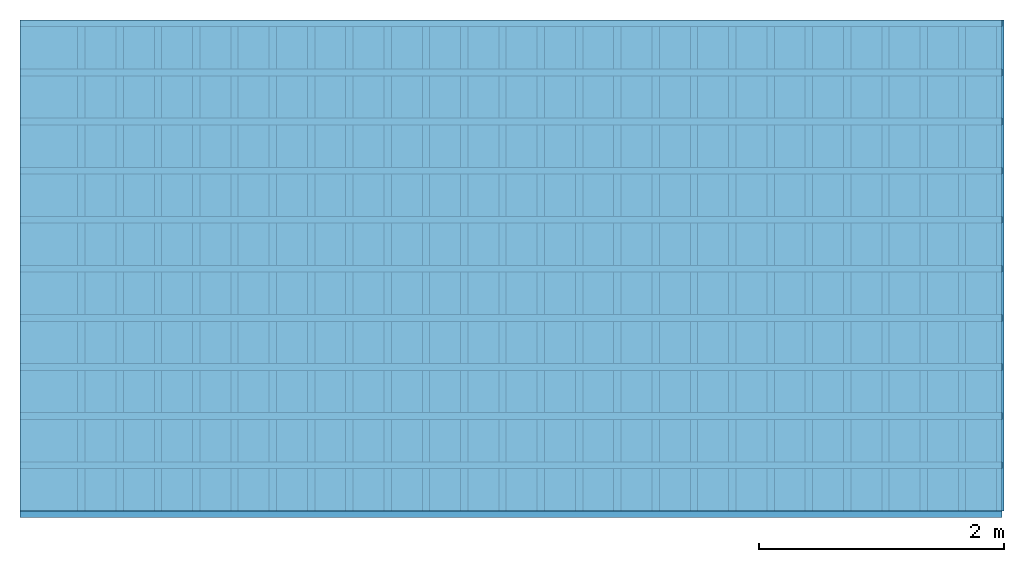
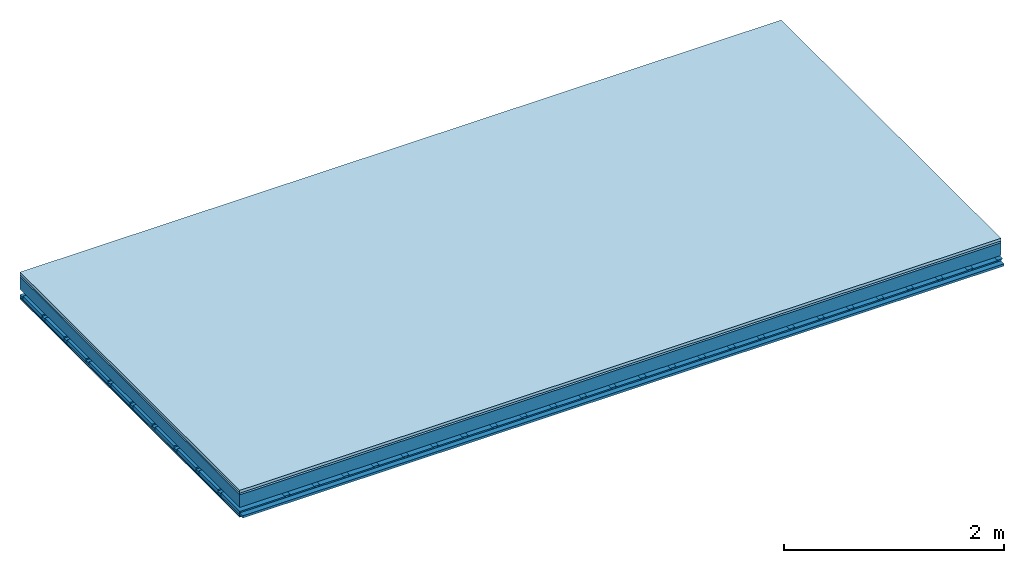
# One storey: 4 members, 4 plates, 1 element without a shape of its own.
"""IFC4 building model written with IfcOpenShell, lengths in metres."""

from ifc_helpers import new_model, si_unit, derived_unit, direction, frame, frame_2d, origin, origin_with_axes, place, context, project, spatial, polyline, rectangle, outline, extrude, material, layer, layer_set, type_object, element, aggregate, save


model = new_model("IFC4")

# Units and contexts
plan_context = context("Plan", 3, precision=1e-05, world=origin(), true_north=direction((0.0, 1.0)))
model_context = context("Model", 3, precision=1e-05, world=origin(), true_north=direction((0.0, 1.0)))
ifc_project = project(units=[si_unit("LENGTHUNIT", "METRE"), derived_unit("SOUNDPRESSUREUNIT", [(si_unit("PRESSUREUNIT", "PASCAL", prefix="MICRO"), 0)]), si_unit("ENERGYUNIT", "JOULE", prefix="MEGA"), si_unit("MASSUNIT", "GRAM", prefix="KILO"), derived_unit("THERMALTRANSMITTANCEUNIT", [(si_unit("POWERUNIT", "WATT"), 1), (si_unit("AREAUNIT", "SQUARE_METRE"), -1), (si_unit("THERMODYNAMICTEMPERATUREUNIT", "KELVIN"), -1)]), derived_unit("AREADENSITYUNIT", [(si_unit("MASSUNIT", "GRAM", prefix="KILO"), 1), (si_unit("AREAUNIT", "SQUARE_METRE"), -1)]), derived_unit("USERDEFINED", [(si_unit("ENERGYUNIT", "JOULE", prefix="MEGA"), 1), (si_unit("AREAUNIT", "SQUARE_METRE"), -1)])], contexts=[plan_context, model_context])

# Site, building, storey
site = spatial("IfcSite", under=ifc_project)
building_placement = place(None, origin())
building = spatial("IfcBuilding", under=site, at=building_placement)
storey_placement = place(building_placement, origin())
storey = spatial("IfcBuildingStorey", under=building, at=storey_placement)

# Slab, members, plates
ifc_material_1 = material(Name="Phone Star TRI", Category="03.013")
ifc_layer_1 = layer(ifc_material_1, 0.03, Name="On-material")
ifc_material_2 = material(Name="Floor 140", Category="10.009")
ifc_layer_2 = layer(ifc_material_2, 0.02, Name="Impact sound insulation")
ifc_material_3 = material(Name="no composite action")
ifc_layer_3 = layer(ifc_material_3, 0.0, Name="Bond")
ifc_layer_4 = layer(None, 0.14, Name="Supporting structure")
ifc_layer_5 = layer(ifc_material_3, 0.0, Name="Bond")
ifc_layer_6 = layer(None, 0.06, Name="Coupling")
ifc_layer_7 = layer(None, 0.025, Name="Battens / profiles")
ifc_layer_8 = layer(ifc_material_1, 0.0125, Name="Ceiling covering 1st layer")
ifc_material_4 = material(Name="Plasterboard type A", Category="03.008")
ifc_layer_9 = layer(ifc_material_4, 0.0125, Name="Ceiling covering layer 2")
ifc_material_5 = material(Name="joints", Category="04.017")
ifc_layer_10 = layer(ifc_material_5, 0.0, Name="Surface / treatment")
ifc_layer_set = layer_set([ifc_layer_1, ifc_layer_2, ifc_layer_3, ifc_layer_4, ifc_layer_5, ifc_layer_6, ifc_layer_7, ifc_layer_8, ifc_layer_9, ifc_layer_10])
slab_type = type_object("IfcSlabType", Name="A2527", PredefinedType="NOTDEFINED", material=ifc_layer_set)
slab_placement = place(None, frame((0.0, 0.0, 0.0), z_axis=(0.0, 0.0, -1.0), x_axis=(1.0, 0.0, 0.0)))
slab = element("IfcSlab", 1, at=slab_placement, inside=storey, type_object=slab_type, material=ifc_layer_set, Name="Slab #1")
ifc_material_6 = material()
member_1_placement = place(slab_placement, origin())
member_1 = element("IfcMember", 2, at=member_1_placement, material=ifc_material_6, Name="Supporting structure", context=plan_context, shape_type="SweptSolid", body=[
    extrude(rectangle(XDim=1.0, YDim=0.14, at=frame_2d((0.5, 0.07), x_axis=(1.0, 0.0))), frame((0.0, 4.0, 0.05), z_axis=(0.0, -1.0, 0.0), x_axis=(1.0, 0.0, 0.0)), (0.0, 0.0, 1.0), 4.0),
    extrude(rectangle(XDim=1.0, YDim=0.14, at=frame_2d((0.5, 0.07), x_axis=(1.0, 0.0))), frame((1.0, 4.0, 0.05), z_axis=(0.0, -1.0, 0.0), x_axis=(1.0, 0.0, 0.0)), (0.0, 0.0, 1.0), 4.0),
    extrude(rectangle(XDim=1.0, YDim=0.14, at=frame_2d((0.5, 0.07), x_axis=(1.0, 0.0))), frame((2.0, 4.0, 0.05), z_axis=(0.0, -1.0, 0.0), x_axis=(1.0, 0.0, 0.0)), (0.0, 0.0, 1.0), 4.0),
    extrude(rectangle(XDim=1.0, YDim=0.14, at=frame_2d((0.5, 0.07), x_axis=(1.0, 0.0))), frame((3.0, 4.0, 0.05), z_axis=(0.0, -1.0, 0.0), x_axis=(1.0, 0.0, 0.0)), (0.0, 0.0, 1.0), 4.0),
    extrude(rectangle(XDim=1.0, YDim=0.14, at=frame_2d((0.5, 0.07), x_axis=(1.0, 0.0))), frame((4.0, 4.0, 0.05), z_axis=(0.0, -1.0, 0.0), x_axis=(1.0, 0.0, 0.0)), (0.0, 0.0, 1.0), 4.0),
    extrude(rectangle(XDim=1.0, YDim=0.14, at=frame_2d((0.5, 0.07), x_axis=(1.0, 0.0))), frame((5.0, 4.0, 0.05), z_axis=(0.0, -1.0, 0.0), x_axis=(1.0, 0.0, 0.0)), (0.0, 0.0, 1.0), 4.0),
    extrude(rectangle(XDim=1.0, YDim=0.14, at=frame_2d((0.5, 0.07), x_axis=(1.0, 0.0))), frame((6.0, 4.0, 0.05), z_axis=(0.0, -1.0, 0.0), x_axis=(1.0, 0.0, 0.0)), (0.0, 0.0, 1.0), 4.0),
    extrude(rectangle(XDim=1.0, YDim=0.14, at=frame_2d((0.5, 0.07), x_axis=(1.0, 0.0))), frame((7.0, 4.0, 0.05), z_axis=(0.0, -1.0, 0.0), x_axis=(1.0, 0.0, 0.0)), (0.0, 0.0, 1.0), 4.0),
])
ifc_material_7 = material()
member_2_placement = place(slab_placement, origin())
member_2 = element("IfcMember", 3, at=member_2_placement, material=ifc_material_7, Name="Coupling", context=plan_context, shape_type="SweptSolid", body=[
    extrude(outline(polyline([(0.0, 0.0), (0.06, 0.0), (0.04, 0.02), (0.02, 0.02), (0.0, 0.0)])), frame((0.47, 4.0, 0.23), z_axis=(0.0, -1.0, 0.0), x_axis=(1.0, 0.0, 0.0)), (0.0, 0.0, 1.0), 4.0),
    extrude(outline(polyline([(0.0, 0.0), (0.06, 0.0), (0.04, 0.02), (0.02, 0.02), (0.0, 0.0)])), frame((0.782, 4.0, 0.23), z_axis=(0.0, -1.0, 0.0), x_axis=(1.0, 0.0, 0.0)), (0.0, 0.0, 1.0), 4.0),
    extrude(outline(polyline([(0.0, 0.0), (0.06, 0.0), (0.04, 0.02), (0.02, 0.02), (0.0, 0.0)])), frame((1.094, 4.0, 0.23), z_axis=(0.0, -1.0, 0.0), x_axis=(1.0, 0.0, 0.0)), (0.0, 0.0, 1.0), 4.0),
    extrude(outline(polyline([(0.0, 0.0), (0.06, 0.0), (0.04, 0.02), (0.02, 0.02), (0.0, 0.0)])), frame((1.406, 4.0, 0.23), z_axis=(0.0, -1.0, 0.0), x_axis=(1.0, 0.0, 0.0)), (0.0, 0.0, 1.0), 4.0),
    extrude(outline(polyline([(0.0, 0.0), (0.06, 0.0), (0.04, 0.02), (0.02, 0.02), (0.0, 0.0)])), frame((1.718, 4.0, 0.23), z_axis=(0.0, -1.0, 0.0), x_axis=(1.0, 0.0, 0.0)), (0.0, 0.0, 1.0), 4.0),
    extrude(outline(polyline([(0.0, 0.0), (0.06, 0.0), (0.04, 0.02), (0.02, 0.02), (0.0, 0.0)])), frame((2.03, 4.0, 0.23), z_axis=(0.0, -1.0, 0.0), x_axis=(1.0, 0.0, 0.0)), (0.0, 0.0, 1.0), 4.0),
    extrude(outline(polyline([(0.0, 0.0), (0.06, 0.0), (0.04, 0.02), (0.02, 0.02), (0.0, 0.0)])), frame((2.342, 4.0, 0.23), z_axis=(0.0, -1.0, 0.0), x_axis=(1.0, 0.0, 0.0)), (0.0, 0.0, 1.0), 4.0),
    extrude(outline(polyline([(0.0, 0.0), (0.06, 0.0), (0.04, 0.02), (0.02, 0.02), (0.0, 0.0)])), frame((2.654, 4.0, 0.23), z_axis=(0.0, -1.0, 0.0), x_axis=(1.0, 0.0, 0.0)), (0.0, 0.0, 1.0), 4.0),
    extrude(outline(polyline([(0.0, 0.0), (0.06, 0.0), (0.04, 0.02), (0.02, 0.02), (0.0, 0.0)])), frame((2.966, 4.0, 0.23), z_axis=(0.0, -1.0, 0.0), x_axis=(1.0, 0.0, 0.0)), (0.0, 0.0, 1.0), 4.0),
    extrude(outline(polyline([(0.0, 0.0), (0.06, 0.0), (0.04, 0.02), (0.02, 0.02), (0.0, 0.0)])), frame((3.278, 4.0, 0.23), z_axis=(0.0, -1.0, 0.0), x_axis=(1.0, 0.0, 0.0)), (0.0, 0.0, 1.0), 4.0),
    extrude(outline(polyline([(0.0, 0.0), (0.06, 0.0), (0.04, 0.02), (0.02, 0.02), (0.0, 0.0)])), frame((3.59, 4.0, 0.23), z_axis=(0.0, -1.0, 0.0), x_axis=(1.0, 0.0, 0.0)), (0.0, 0.0, 1.0), 4.0),
    extrude(outline(polyline([(0.0, 0.0), (0.06, 0.0), (0.04, 0.02), (0.02, 0.02), (0.0, 0.0)])), frame((3.902, 4.0, 0.23), z_axis=(0.0, -1.0, 0.0), x_axis=(1.0, 0.0, 0.0)), (0.0, 0.0, 1.0), 4.0),
    extrude(outline(polyline([(0.0, 0.0), (0.06, 0.0), (0.04, 0.02), (0.02, 0.02), (0.0, 0.0)])), frame((4.214, 4.0, 0.23), z_axis=(0.0, -1.0, 0.0), x_axis=(1.0, 0.0, 0.0)), (0.0, 0.0, 1.0), 4.0),
    extrude(outline(polyline([(0.0, 0.0), (0.06, 0.0), (0.04, 0.02), (0.02, 0.02), (0.0, 0.0)])), frame((4.526, 4.0, 0.23), z_axis=(0.0, -1.0, 0.0), x_axis=(1.0, 0.0, 0.0)), (0.0, 0.0, 1.0), 4.0),
    extrude(outline(polyline([(0.0, 0.0), (0.06, 0.0), (0.04, 0.02), (0.02, 0.02), (0.0, 0.0)])), frame((4.838, 4.0, 0.23), z_axis=(0.0, -1.0, 0.0), x_axis=(1.0, 0.0, 0.0)), (0.0, 0.0, 1.0), 4.0),
    extrude(outline(polyline([(0.0, 0.0), (0.06, 0.0), (0.04, 0.02), (0.02, 0.02), (0.0, 0.0)])), frame((5.15, 4.0, 0.23), z_axis=(0.0, -1.0, 0.0), x_axis=(1.0, 0.0, 0.0)), (0.0, 0.0, 1.0), 4.0),
    extrude(outline(polyline([(0.0, 0.0), (0.06, 0.0), (0.04, 0.02), (0.02, 0.02), (0.0, 0.0)])), frame((5.462, 4.0, 0.23), z_axis=(0.0, -1.0, 0.0), x_axis=(1.0, 0.0, 0.0)), (0.0, 0.0, 1.0), 4.0),
    extrude(outline(polyline([(0.0, 0.0), (0.06, 0.0), (0.04, 0.02), (0.02, 0.02), (0.0, 0.0)])), frame((5.774, 4.0, 0.23), z_axis=(0.0, -1.0, 0.0), x_axis=(1.0, 0.0, 0.0)), (0.0, 0.0, 1.0), 4.0),
    extrude(outline(polyline([(0.0, 0.0), (0.06, 0.0), (0.04, 0.02), (0.02, 0.02), (0.0, 0.0)])), frame((6.086, 4.0, 0.23), z_axis=(0.0, -1.0, 0.0), x_axis=(1.0, 0.0, 0.0)), (0.0, 0.0, 1.0), 4.0),
    extrude(outline(polyline([(0.0, 0.0), (0.06, 0.0), (0.04, 0.02), (0.02, 0.02), (0.0, 0.0)])), frame((6.398, 4.0, 0.23), z_axis=(0.0, -1.0, 0.0), x_axis=(1.0, 0.0, 0.0)), (0.0, 0.0, 1.0), 4.0),
    extrude(outline(polyline([(0.0, 0.0), (0.06, 0.0), (0.04, 0.02), (0.02, 0.02), (0.0, 0.0)])), frame((6.71, 4.0, 0.23), z_axis=(0.0, -1.0, 0.0), x_axis=(1.0, 0.0, 0.0)), (0.0, 0.0, 1.0), 4.0),
    extrude(outline(polyline([(0.0, 0.0), (0.06, 0.0), (0.04, 0.02), (0.02, 0.02), (0.0, 0.0)])), frame((7.022, 4.0, 0.23), z_axis=(0.0, -1.0, 0.0), x_axis=(1.0, 0.0, 0.0)), (0.0, 0.0, 1.0), 4.0),
    extrude(outline(polyline([(0.0, 0.0), (0.06, 0.0), (0.04, 0.02), (0.02, 0.02), (0.0, 0.0)])), frame((7.334, 4.0, 0.23), z_axis=(0.0, -1.0, 0.0), x_axis=(1.0, 0.0, 0.0)), (0.0, 0.0, 1.0), 4.0),
    extrude(outline(polyline([(0.0, 0.0), (0.06, 0.0), (0.04, 0.02), (0.02, 0.02), (0.0, 0.0)])), frame((7.646, 4.0, 0.23), z_axis=(0.0, -1.0, 0.0), x_axis=(1.0, 0.0, 0.0)), (0.0, 0.0, 1.0), 4.0),
    extrude(outline(polyline([(0.0, 0.0), (0.06, 0.0), (0.04, 0.02), (0.02, 0.02), (0.0, 0.0)])), frame((7.958, 4.0, 0.23), z_axis=(0.0, -1.0, 0.0), x_axis=(1.0, 0.0, 0.0)), (0.0, 0.0, 1.0), 4.0),
])
ifc_material_8 = material()
member_3_placement = place(slab_placement, origin())
member_3 = element("IfcMember", 4, at=member_3_placement, material=ifc_material_8, Name="Battens / profiles", context=plan_context, shape_type="SweptSolid", body=[
    extrude(rectangle(XDim=0.055, YDim=0.025, at=frame_2d((0.0275, 0.0125), x_axis=(1.0, 0.0))), frame((0.0, 0.0, 0.25), z_axis=(1.0, 0.0, 0.0), x_axis=(0.0, 1.0, 0.0)), (0.0, 0.0, 1.0), 8.0),
    extrude(rectangle(XDim=0.055, YDim=0.025, at=frame_2d((0.0275, 0.0125), x_axis=(1.0, 0.0))), frame((0.0, 0.4, 0.25), z_axis=(1.0, 0.0, 0.0), x_axis=(0.0, 1.0, 0.0)), (0.0, 0.0, 1.0), 8.0),
    extrude(rectangle(XDim=0.055, YDim=0.025, at=frame_2d((0.0275, 0.0125), x_axis=(1.0, 0.0))), frame((0.0, 0.8, 0.25), z_axis=(1.0, 0.0, 0.0), x_axis=(0.0, 1.0, 0.0)), (0.0, 0.0, 1.0), 8.0),
    extrude(rectangle(XDim=0.055, YDim=0.025, at=frame_2d((0.0275, 0.0125), x_axis=(1.0, 0.0))), frame((0.0, 1.2, 0.25), z_axis=(1.0, 0.0, 0.0), x_axis=(0.0, 1.0, 0.0)), (0.0, 0.0, 1.0), 8.0),
    extrude(rectangle(XDim=0.055, YDim=0.025, at=frame_2d((0.0275, 0.0125), x_axis=(1.0, 0.0))), frame((0.0, 1.6, 0.25), z_axis=(1.0, 0.0, 0.0), x_axis=(0.0, 1.0, 0.0)), (0.0, 0.0, 1.0), 8.0),
    extrude(rectangle(XDim=0.055, YDim=0.025, at=frame_2d((0.0275, 0.0125), x_axis=(1.0, 0.0))), frame((0.0, 2.0, 0.25), z_axis=(1.0, 0.0, 0.0), x_axis=(0.0, 1.0, 0.0)), (0.0, 0.0, 1.0), 8.0),
    extrude(rectangle(XDim=0.055, YDim=0.025, at=frame_2d((0.0275, 0.0125), x_axis=(1.0, 0.0))), frame((0.0, 2.4, 0.25), z_axis=(1.0, 0.0, 0.0), x_axis=(0.0, 1.0, 0.0)), (0.0, 0.0, 1.0), 8.0),
    extrude(rectangle(XDim=0.055, YDim=0.025, at=frame_2d((0.0275, 0.0125), x_axis=(1.0, 0.0))), frame((0.0, 2.8, 0.25), z_axis=(1.0, 0.0, 0.0), x_axis=(0.0, 1.0, 0.0)), (0.0, 0.0, 1.0), 8.0),
    extrude(rectangle(XDim=0.055, YDim=0.025, at=frame_2d((0.0275, 0.0125), x_axis=(1.0, 0.0))), frame((0.0, 3.2, 0.25), z_axis=(1.0, 0.0, 0.0), x_axis=(0.0, 1.0, 0.0)), (0.0, 0.0, 1.0), 8.0),
    extrude(rectangle(XDim=0.055, YDim=0.025, at=frame_2d((0.0275, 0.0125), x_axis=(1.0, 0.0))), frame((0.0, 3.6, 0.25), z_axis=(1.0, 0.0, 0.0), x_axis=(0.0, 1.0, 0.0)), (0.0, 0.0, 1.0), 8.0),
    extrude(rectangle(XDim=0.055, YDim=0.025, at=frame_2d((0.0275, 0.0125), x_axis=(1.0, 0.0))), frame((0.0, 4.0, 0.25), z_axis=(1.0, 0.0, 0.0), x_axis=(0.0, 1.0, 0.0)), (0.0, 0.0, 1.0), 8.0),
])
ifc_material_9 = material()
member_4_placement = place(slab_placement, origin())
member_4 = element("IfcMember", 5, at=member_4_placement, material=ifc_material_9, Name="Cavity", context=plan_context, shape_type="SweptSolid", body=[
    extrude(rectangle(XDim=0.345, YDim=0.04, at=frame_2d((0.1725, 0.02), x_axis=(1.0, 0.0))), frame((0.0, 0.055, 0.235), z_axis=(1.0, 0.0, 0.0), x_axis=(0.0, 1.0, 0.0)), (0.0, 0.0, 1.0), 8.0),
    extrude(rectangle(XDim=0.345, YDim=0.04, at=frame_2d((0.1725, 0.02), x_axis=(1.0, 0.0))), frame((0.0, 0.455, 0.235), z_axis=(1.0, 0.0, 0.0), x_axis=(0.0, 1.0, 0.0)), (0.0, 0.0, 1.0), 8.0),
    extrude(rectangle(XDim=0.345, YDim=0.04, at=frame_2d((0.1725, 0.02), x_axis=(1.0, 0.0))), frame((0.0, 0.855, 0.235), z_axis=(1.0, 0.0, 0.0), x_axis=(0.0, 1.0, 0.0)), (0.0, 0.0, 1.0), 8.0),
    extrude(rectangle(XDim=0.345, YDim=0.04, at=frame_2d((0.1725, 0.02), x_axis=(1.0, 0.0))), frame((0.0, 1.255, 0.235), z_axis=(1.0, 0.0, 0.0), x_axis=(0.0, 1.0, 0.0)), (0.0, 0.0, 1.0), 8.0),
    extrude(rectangle(XDim=0.345, YDim=0.04, at=frame_2d((0.1725, 0.02), x_axis=(1.0, 0.0))), frame((0.0, 1.655, 0.235), z_axis=(1.0, 0.0, 0.0), x_axis=(0.0, 1.0, 0.0)), (0.0, 0.0, 1.0), 8.0),
    extrude(rectangle(XDim=0.345, YDim=0.04, at=frame_2d((0.1725, 0.02), x_axis=(1.0, 0.0))), frame((0.0, 2.055, 0.235), z_axis=(1.0, 0.0, 0.0), x_axis=(0.0, 1.0, 0.0)), (0.0, 0.0, 1.0), 8.0),
    extrude(rectangle(XDim=0.345, YDim=0.04, at=frame_2d((0.1725, 0.02), x_axis=(1.0, 0.0))), frame((0.0, 2.455, 0.235), z_axis=(1.0, 0.0, 0.0), x_axis=(0.0, 1.0, 0.0)), (0.0, 0.0, 1.0), 8.0),
    extrude(rectangle(XDim=0.345, YDim=0.04, at=frame_2d((0.1725, 0.02), x_axis=(1.0, 0.0))), frame((0.0, 2.855, 0.235), z_axis=(1.0, 0.0, 0.0), x_axis=(0.0, 1.0, 0.0)), (0.0, 0.0, 1.0), 8.0),
    extrude(rectangle(XDim=0.345, YDim=0.04, at=frame_2d((0.1725, 0.02), x_axis=(1.0, 0.0))), frame((0.0, 3.255, 0.235), z_axis=(1.0, 0.0, 0.0), x_axis=(0.0, 1.0, 0.0)), (0.0, 0.0, 1.0), 8.0),
    extrude(rectangle(XDim=0.345, YDim=0.04, at=frame_2d((0.1725, 0.02), x_axis=(1.0, 0.0))), frame((0.0, 3.655, 0.235), z_axis=(1.0, 0.0, 0.0), x_axis=(0.0, 1.0, 0.0)), (0.0, 0.0, 1.0), 8.0),
])
plate_1_placement = place(slab_placement, origin())
plate_1 = element("IfcPlate", 6, at=plate_1_placement, material=ifc_material_1, Name="On-material", context=plan_context, shape_type="SweptSolid", body=[
    extrude(rectangle(XDim=8.0, YDim=4.0, at=frame_2d((4.0, 2.0), x_axis=(1.0, 0.0))), origin_with_axes(), (0.0, 0.0, 1.0), 0.03),
])
plate_2_placement = place(slab_placement, origin())
plate_2 = element("IfcPlate", 7, at=plate_2_placement, material=ifc_material_2, Name="Impact sound insulation", context=plan_context, shape_type="SweptSolid", body=[
    extrude(rectangle(XDim=8.0, YDim=4.0, at=frame_2d((4.0, 2.0), x_axis=(1.0, 0.0))), frame((0.0, 0.0, 0.03), z_axis=(0.0, 0.0, 1.0), x_axis=(1.0, 0.0, 0.0)), (0.0, 0.0, 1.0), 0.02),
])
plate_3_placement = place(slab_placement, origin())
plate_3 = element("IfcPlate", 8, at=plate_3_placement, material=ifc_material_1, Name="Ceiling covering 1st layer", context=plan_context, shape_type="SweptSolid", body=[
    extrude(rectangle(XDim=8.0, YDim=4.0, at=frame_2d((4.0, 2.0), x_axis=(1.0, 0.0))), frame((0.0, 0.0, 0.275), z_axis=(0.0, 0.0, 1.0), x_axis=(1.0, 0.0, 0.0)), (0.0, 0.0, 1.0), 0.0125),
])
plate_4_placement = place(slab_placement, origin())
plate_4 = element("IfcPlate", 9, at=plate_4_placement, material=ifc_material_4, Name="Ceiling covering layer 2", context=plan_context, shape_type="SweptSolid", body=[
    extrude(rectangle(XDim=8.0, YDim=4.0, at=frame_2d((4.0, 2.0), x_axis=(1.0, 0.0))), frame((0.0, 0.0, 0.2875), z_axis=(0.0, 0.0, 1.0), x_axis=(1.0, 0.0, 0.0)), (0.0, 0.0, 1.0), 0.0125),
])
aggregate(slab, [plate_1, plate_2, member_1, member_2, member_3, member_4, plate_3, plate_4])

save(model, "model.ifc")
